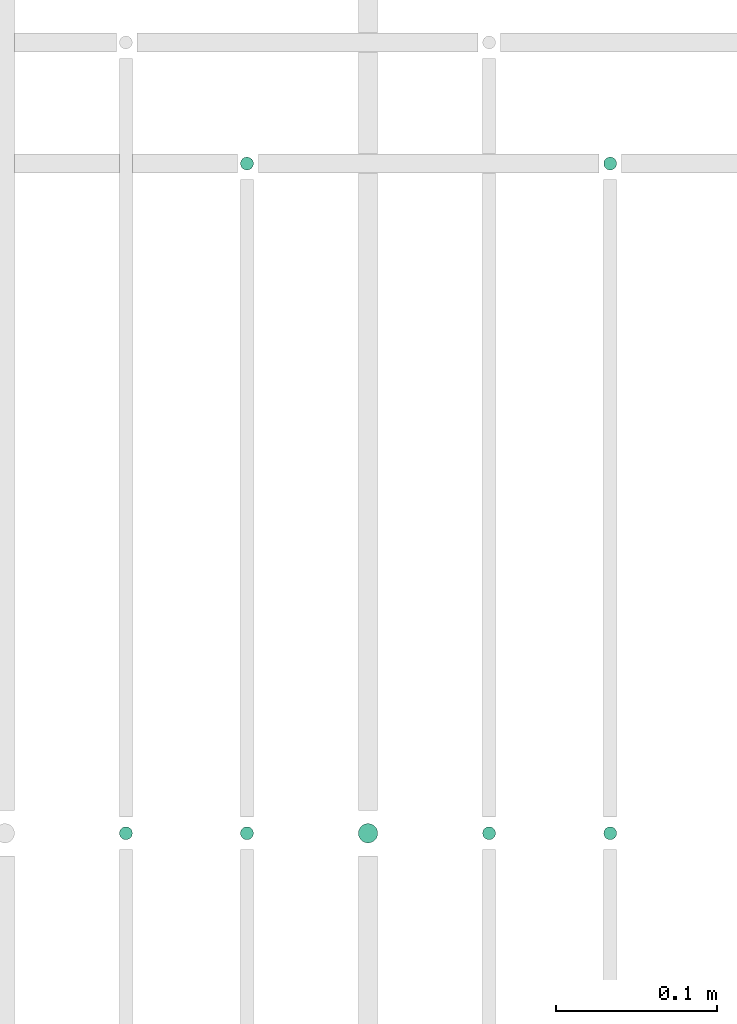
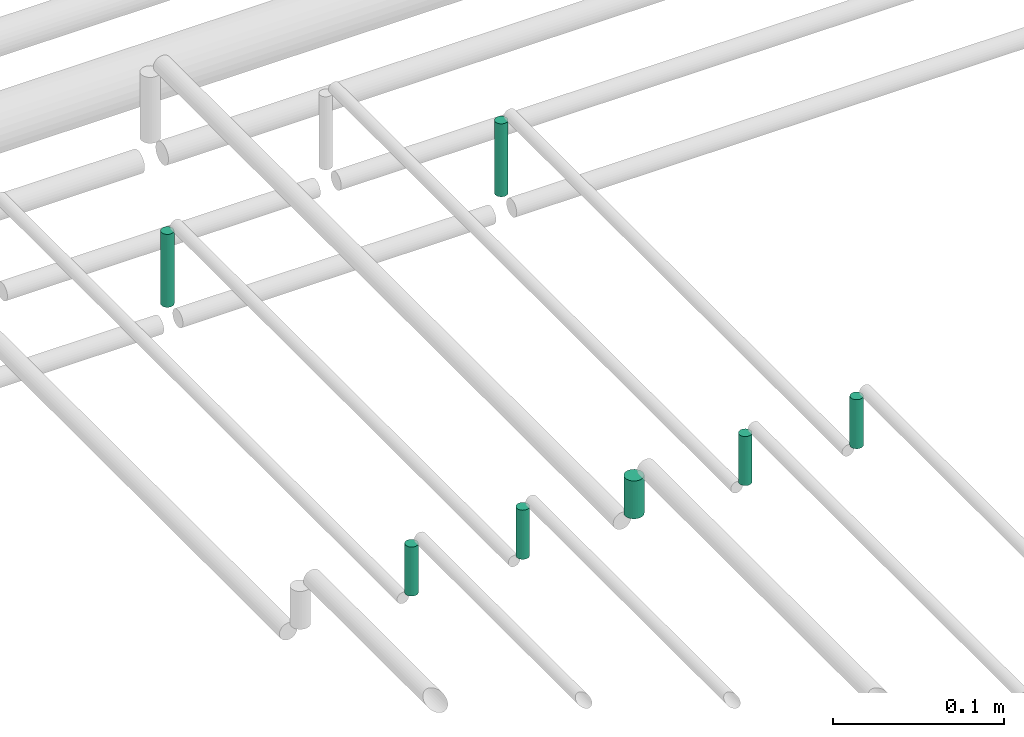
# One storey, part 280 of 331: 7 flow segments.
"""IFC2X3 building model written with IfcOpenShell, lengths in millimetres."""

import ifcopenshell
import ifcopenshell.guid

model = None  # the IFC model being written
_history = None  # IfcOwnerHistory: only IFC2X3 demands one
_inside = {}  # id of a spatial element -> (the spatial element, [elements in it])
_under = {}  # id of a project, library or spatial element -> (it, [spatial elements below it])
_declared = {}  # id of a project -> (the project, [libraries it declares])
_typed = {}  # id of a type object -> (the type object, [elements of that type])
_made_of = {}  # id of a material, layer set ... -> (it, [elements and type objects made of it])


def new_model(schema):
    """Start an empty IFC model of exactly this schema.

    Asked for "IFC4X3", IfcOpenShell would pick the latest addendum, in which some entities
    have other attributes; the version numbers below select the first issue.
    IFC2X3 requires an IfcOwnerHistory on every rooted entity: one is made here for all.
    """
    global model, _history
    if schema == "IFC4X3":
        model = ifcopenshell.file(schema_version=(4, 3, 0, 0))
    else:
        model = ifcopenshell.file(schema=schema)
    _inside.clear()
    _under.clear()
    _declared.clear()
    _typed.clear()
    _made_of.clear()
    _history = None
    if model.schema == "IFC2X3":
        org = make("IfcOrganization", Name="unknown")
        user = make(
            "IfcPersonAndOrganization",
            ThePerson=make("IfcPerson", FamilyName="unknown"),
            TheOrganization=org,
        )
        app = make(
            "IfcApplication",
            ApplicationDeveloper=org,
            Version="unknown",
            ApplicationFullName="unknown",
            ApplicationIdentifier="unknown",
        )
        _history = make(
            "IfcOwnerHistory",
            OwningUser=user,
            OwningApplication=app,
            ChangeAction="ADDED",
            CreationDate=0,
        )
    return model


def make(cls, **values):
    """One entity of the class cls with the attributes given. An attribute that is None is left unset."""
    return model.create_entity(
        cls, **{name: value for name, value in values.items() if value is not None}
    )


def entity(cls, *values):
    """Any entity or typed value of the class cls, its attributes in the order of the schema. None: left unset."""
    e = model.create_entity(cls)
    for i, value in enumerate(values):
        if value is not None:
            e[i] = value
    return e


def rooted(cls, **values):
    """An entity with a GlobalId (a new one), such as an element, a storey or a relation."""
    return make(cls, GlobalId=ifcopenshell.guid.new(), OwnerHistory=_history, **values)


def si_unit(unit_type, name, prefix=None):
    """IfcSIUnit, for example si_unit("LENGTHUNIT", "METRE", prefix="MILLI")."""
    return make("IfcSIUnit", UnitType=unit_type, Prefix=prefix, Name=name)


def converted_unit(unit_type, name, factor, base, dimensions=None, offset=None):
    """IfcConversionBasedUnit, such as the inch: factor (a typed value) times the base unit."""
    return make(
        "IfcConversionBasedUnit"
        if offset is None
        else "IfcConversionBasedUnitWithOffset",
        ConversionOffset=offset,
        Dimensions=None
        if dimensions is None
        else entity("IfcDimensionalExponents", *dimensions),
        UnitType=unit_type,
        Name=name,
        ConversionFactor=make(
            "IfcMeasureWithUnit", ValueComponent=factor, UnitComponent=base
        ),
    )


def derived_unit(unit_type, elements):
    """IfcDerivedUnit: a product of units, each with its exponent."""
    return make(
        "IfcDerivedUnit",
        Elements=[
            make("IfcDerivedUnitElement", Unit=unit, Exponent=power)
            for unit, power in elements
        ],
        UnitType=unit_type,
    )


def assignment(units):
    """IfcUnitAssignment: the units of a project."""
    return None if units is None else make("IfcUnitAssignment", Units=units)


def point(xyz):
    """IfcCartesianPoint."""
    return None if xyz is None else make("IfcCartesianPoint", Coordinates=xyz)


def direction(xyz):
    """IfcDirection."""
    return None if xyz is None else make("IfcDirection", DirectionRatios=xyz)


def frame(location, z_axis=None, x_axis=None):
    """IfcAxis2Placement3D, a coordinate frame: its origin and axes. An axis left out is left unset."""
    return make(
        "IfcAxis2Placement3D",
        Location=point(location),
        Axis=direction(z_axis),
        RefDirection=direction(x_axis),
    )


def frame_2d(location, x_axis=None):
    """IfcAxis2Placement2D, a coordinate frame in the plane: its origin and x axis."""
    return make(
        "IfcAxis2Placement2D", Location=point(location), RefDirection=direction(x_axis)
    )


def origin():
    """The frame at (0, 0, 0) with its axes left unset."""
    return frame((0.0, 0.0, 0.0))


def origin_2d_with_axis():
    """The frame at (0, 0) in the plane with the x axis (1, 0) written out."""
    return frame_2d((0.0, 0.0), x_axis=(1.0, 0.0))


def place(relative_to, where):
    """IfcLocalPlacement: puts the frame where relative to a parent placement (None: the world)."""
    return make(
        "IfcLocalPlacement", PlacementRelTo=relative_to, RelativePlacement=where
    )


def context(
    kind, dimensions, precision=None, world=None, true_north=None, identifier=None
):
    """IfcGeometricRepresentationContext, for example the 3D "Model" context."""
    return make(
        "IfcGeometricRepresentationContext",
        ContextIdentifier=identifier,
        ContextType=kind,
        CoordinateSpaceDimension=dimensions,
        Precision=precision,
        WorldCoordinateSystem=world,
        TrueNorth=true_north,
    )


def subcontext(parent, identifier, kind, view, scale=None):
    """IfcGeometricRepresentationSubContext, for example "Body" below "Model"."""
    return make(
        "IfcGeometricRepresentationSubContext",
        ContextIdentifier=identifier,
        ContextType=kind,
        ParentContext=parent,
        TargetScale=scale,
        TargetView=view,
    )


def project(units=None, contexts=None):
    """IfcProject with its units and contexts."""
    return rooted(
        "IfcProject",
        Name="project",
        RepresentationContexts=contexts,
        UnitsInContext=assignment(units),
    )


def spatial(cls, under=None, at=None, **own):
    """A site, building, storey or space (cls), placed at a placement, below another one or the project."""
    s = rooted(cls, ObjectPlacement=at, **own)
    if under is not None:
        _under.setdefault(under.id(), (under, []))[1].append(s)
    return s


def profile(cls, at=None, kind="AREA", **sizes):
    """A parametric profile (cls). Its sizes go by their IFC names, for example OverallWidth=200.0."""
    return make(cls, ProfileType=kind, Position=at, **sizes)


def circle(**sizes):
    """IfcCircleProfileDef."""
    return profile("IfcCircleProfileDef", **sizes)


def extrude(swept, where, along, depth):
    """IfcExtrudedAreaSolid: the profile swept, set in the frame where, extruded along a direction by depth."""
    return make(
        "IfcExtrudedAreaSolid",
        SweptArea=swept,
        Position=where,
        ExtrudedDirection=direction(along),
        Depth=depth,
    )


def shape(context_of_items, identifier, shape_type, items):
    """IfcShapeRepresentation: the items that make up one representation, for example the "Body"."""
    return make(
        "IfcShapeRepresentation",
        ContextOfItems=context_of_items,
        RepresentationIdentifier=identifier,
        RepresentationType=shape_type,
        Items=items,
    )


def made_of(thing, what):
    """Note that an element or type object is made of a material, layer set ...; save() writes the relation."""
    if what is not None:
        _made_of.setdefault(what.id(), (what, []))[1].append(thing)
    return thing


def type_object(cls, material=None, **own):
    """A type object (cls), such as IfcWallType, which elements share."""
    return made_of(rooted(cls, **own), material)


def element(
    cls,
    number,
    at=None,
    inside=None,
    cuts=None,
    type_object=None,
    material=None,
    context=None,
    identifier="Body",
    shape_type=None,
    held_by="IfcProductDefinitionShape",
    body=None,
    shapes=None,
    **own,
):
    """One element of the class cls, such as IfcWall. Its Tag is "e" and its number.

    at: its placement. inside: the storey or other place that contains it. cuts: it is an
    opening in that element (IfcRelVoidsElement). A single representation is given by context,
    identifier, shape_type and body (its items); several are given by shapes. held_by: the class
    of the entity that holds the representations. save() writes the other relations.
    """
    e = rooted(cls, Tag="e%d" % number, ObjectPlacement=at, **own)
    if body is not None:
        shapes = [shape(context, identifier, shape_type, body)]
    if shapes is not None:
        e.Representation = make(held_by, Representations=shapes)
    if inside is not None:
        _inside.setdefault(inside.id(), (inside, []))[1].append(e)
    if cuts is not None:
        rooted(
            "IfcRelVoidsElement", RelatingBuildingElement=cuts, RelatedOpeningElement=e
        )
    if type_object is not None:
        _typed.setdefault(type_object.id(), (type_object, []))[1].append(e)
    return made_of(e, material)


def aggregate(whole, parts):
    """IfcRelAggregates: a whole, such as a stair, and the parts it consists of."""
    return rooted("IfcRelAggregates", RelatingObject=whole, RelatedObjects=parts)


def save(model, path):
    """Write the relations noted so far, then the file.

    IfcRelAggregates (storeys below a building ...), IfcRelContainedInSpatialStructure (elements
    in a storey), IfcRelDefinesByType, IfcRelAssociatesMaterial and IfcRelDeclares: one each for
    every whole, place, type object, material and project.
    """
    for whole, parts in _under.values():
        aggregate(whole, parts)
    for where, things in _inside.values():
        rooted(
            "IfcRelContainedInSpatialStructure",
            RelatedElements=things,
            RelatingStructure=where,
        )
    for kind, things in _typed.values():
        rooted("IfcRelDefinesByType", RelatedObjects=things, RelatingType=kind)
    for what, things in _made_of.values():
        rooted("IfcRelAssociatesMaterial", RelatedObjects=things, RelatingMaterial=what)
    for by, libraries in _declared.values():
        rooted("IfcRelDeclares", RelatingContext=by, RelatedDefinitions=libraries)
    model.write(path)


model = new_model("IFC2X3")

# Units and contexts
model_context = context("Model", 3, precision=0.01, world=origin(), true_north=direction((6.12303176911189e-17, 1.0)))
body_context = subcontext(model_context, "Body", "Model", "MODEL_VIEW")
ifc_project = project(units=[si_unit("LENGTHUNIT", "METRE", prefix="MILLI"), si_unit("AREAUNIT", "SQUARE_METRE"), si_unit("VOLUMEUNIT", "CUBIC_METRE"), converted_unit("PLANEANGLEUNIT", "DEGREE", entity("IfcRatioMeasure", 0.0174532925199433), si_unit("PLANEANGLEUNIT", "RADIAN"), dimensions=[0, 0, 0, 0, 0, 0, 0]), si_unit("MASSUNIT", "GRAM", prefix="KILO"), derived_unit("MASSDENSITYUNIT", [(si_unit("MASSUNIT", "GRAM", prefix="KILO"), 1), (si_unit("LENGTHUNIT", "METRE"), -3)]), derived_unit("MOMENTOFINERTIAUNIT", [(si_unit("LENGTHUNIT", "METRE"), 4)]), si_unit("TIMEUNIT", "SECOND"), si_unit("FREQUENCYUNIT", "HERTZ"), si_unit("THERMODYNAMICTEMPERATUREUNIT", "DEGREE_CELSIUS"), derived_unit("THERMALTRANSMITTANCEUNIT", [(si_unit("MASSUNIT", "GRAM", prefix="KILO"), 1), (si_unit("THERMODYNAMICTEMPERATUREUNIT", "KELVIN"), -1), (si_unit("TIMEUNIT", "SECOND"), -3)]), derived_unit("VOLUMETRICFLOWRATEUNIT", [(si_unit("LENGTHUNIT", "METRE"), 3), (si_unit("TIMEUNIT", "SECOND"), -1)]), derived_unit("MASSFLOWRATEUNIT", [(si_unit("MASSUNIT", "GRAM", prefix="KILO"), 1), (si_unit("TIMEUNIT", "SECOND"), -1)]), derived_unit("ROTATIONALFREQUENCYUNIT", [(si_unit("TIMEUNIT", "SECOND"), -1)]), si_unit("ELECTRICCURRENTUNIT", "AMPERE"), si_unit("ELECTRICVOLTAGEUNIT", "VOLT"), si_unit("POWERUNIT", "WATT"), si_unit("FORCEUNIT", "NEWTON", prefix="KILO"), si_unit("ILLUMINANCEUNIT", "LUX"), si_unit("LUMINOUSFLUXUNIT", "LUMEN"), si_unit("LUMINOUSINTENSITYUNIT", "CANDELA"), derived_unit("USERDEFINED", [(si_unit("MASSUNIT", "GRAM", prefix="KILO"), -1), (si_unit("LENGTHUNIT", "METRE"), -2), (si_unit("TIMEUNIT", "SECOND"), 3), (si_unit("LUMINOUSFLUXUNIT", "LUMEN"), 1)]), derived_unit("LINEARVELOCITYUNIT", [(si_unit("LENGTHUNIT", "METRE"), 1), (si_unit("TIMEUNIT", "SECOND"), -1)]), si_unit("PRESSUREUNIT", "PASCAL"), derived_unit("USERDEFINED", [(si_unit("LENGTHUNIT", "METRE"), -2), (si_unit("MASSUNIT", "GRAM", prefix="KILO"), 1), (si_unit("TIMEUNIT", "SECOND"), -2)]), derived_unit("LINEARFORCEUNIT", [(si_unit("MASSUNIT", "GRAM", prefix="KILO"), 1), (si_unit("LENGTHUNIT", "METRE"), 1), (si_unit("TIMEUNIT", "SECOND"), -2), (si_unit("LENGTHUNIT", "METRE"), -1)]), derived_unit("PLANARFORCEUNIT", [(si_unit("MASSUNIT", "GRAM", prefix="KILO"), 1), (si_unit("LENGTHUNIT", "METRE"), 1), (si_unit("TIMEUNIT", "SECOND"), -2), (si_unit("LENGTHUNIT", "METRE"), -2)])], contexts=[model_context])

# Site, building, storey
site_placement = place(None, frame((0.0, -0.00077364408347762, 0.0)))
site = spatial("IfcSite", under=ifc_project, at=site_placement, CompositionType="ELEMENT")
building_placement = place(site_placement, origin())
building = spatial("IfcBuilding", under=site, at=building_placement, CompositionType="ELEMENT")
storey_placement = place(building_placement, origin())
storey = spatial("IfcBuildingStorey", under=building, at=storey_placement, CompositionType="ELEMENT", Elevation=0.0)

# Flow segments
pipe_segment_type = type_object("IfcPipeSegmentType", PredefinedType="NOTDEFINED")
flow_segment_1_placement = place(storey_placement, frame((44639.5706481368, 9394.40472776404, 18463.0)))
element("IfcFlowSegment", 1, at=flow_segment_1_placement, inside=storey, type_object=pipe_segment_type, context=body_context, shape_type="SweptSolid", body=[
    extrude(circle(Radius=4.0, at=origin_2d_with_axis()), frame((5.59527223591499, 5.59527223591607, 0.0), z_axis=(0.0, 0.0, 1.0), x_axis=(-1.0, 0.0, 0.0)), (0.0, 0.0, 1.0), 52.0000000000878),
])
flow_segment_2_placement = place(storey_placement, frame((44864.5706481369, 9394.40472776404, 18463.0)))
element("IfcFlowSegment", 2, at=flow_segment_2_placement, inside=storey, type_object=pipe_segment_type, context=body_context, shape_type="SweptSolid", body=[
    extrude(circle(Radius=4.0, at=frame_2d((0.0, 1.08286712929839e-12), x_axis=(1.0, 0.0))), frame((5.59527223591499, 5.59527223591716, 0.0), z_axis=(0.0, 0.0, 1.0), x_axis=(-1.0, 0.0, 0.0)), (0.0, 0.0, 1.0), 52.00000000009),
])
flow_segment_3_placement = place(storey_placement, frame((44564.5706481368, 8979.55353441903, 18535.0)))
element("IfcFlowSegment", 3, at=flow_segment_3_placement, inside=storey, type_object=pipe_segment_type, context=body_context, shape_type="SweptSolid", body=[
    extrude(circle(Radius=4.0, at=origin_2d_with_axis()), frame((5.59527223591499, 5.59527223591607, 0.0)), (0.0, 0.0, 1.0), 34.9999999999574),
])
flow_segment_4_placement = place(storey_placement, frame((44639.5706481368, 8979.55353441903, 18535.0)))
element("IfcFlowSegment", 4, at=flow_segment_4_placement, inside=storey, type_object=pipe_segment_type, context=body_context, shape_type="SweptSolid", body=[
    extrude(circle(Radius=4.0, at=origin_2d_with_axis()), frame((5.59527223591499, 5.59527223591607, 0.0)), (0.0, 0.0, 1.0), 34.9999999999509),
])
flow_segment_5_placement = place(storey_placement, frame((44712.5706481368, 8977.55353441903, 18539.0)))
element("IfcFlowSegment", 5, at=flow_segment_5_placement, inside=storey, type_object=pipe_segment_type, context=body_context, shape_type="SweptSolid", body=[
    extrude(circle(Radius=6.0, at=origin_2d_with_axis()), frame((7.59527223591454, 7.59527223591562, 0.0)), (0.0, 0.0, 1.0), 26.9999999999202),
])
flow_segment_6_placement = place(storey_placement, frame((44789.5706481368, 8979.55353441903, 18535.0)))
element("IfcFlowSegment", 6, at=flow_segment_6_placement, inside=storey, type_object=pipe_segment_type, context=body_context, shape_type="SweptSolid", body=[
    extrude(circle(Radius=4.0, at=origin_2d_with_axis()), frame((5.59527223591499, 5.59527223591607, 0.0)), (0.0, 0.0, 1.0), 34.9999999999097),
])
flow_segment_7_placement = place(storey_placement, frame((44864.5706481369, 8979.55353441903, 18535.0)))
element("IfcFlowSegment", 7, at=flow_segment_7_placement, inside=storey, type_object=pipe_segment_type, context=body_context, shape_type="SweptSolid", body=[
    extrude(circle(Radius=4.0, at=origin_2d_with_axis()), frame((5.59527223591499, 5.59527223591607, 0.0)), (0.0, 0.0, 1.0), 34.9999999999314),
])

save(model, "model.ifc")
